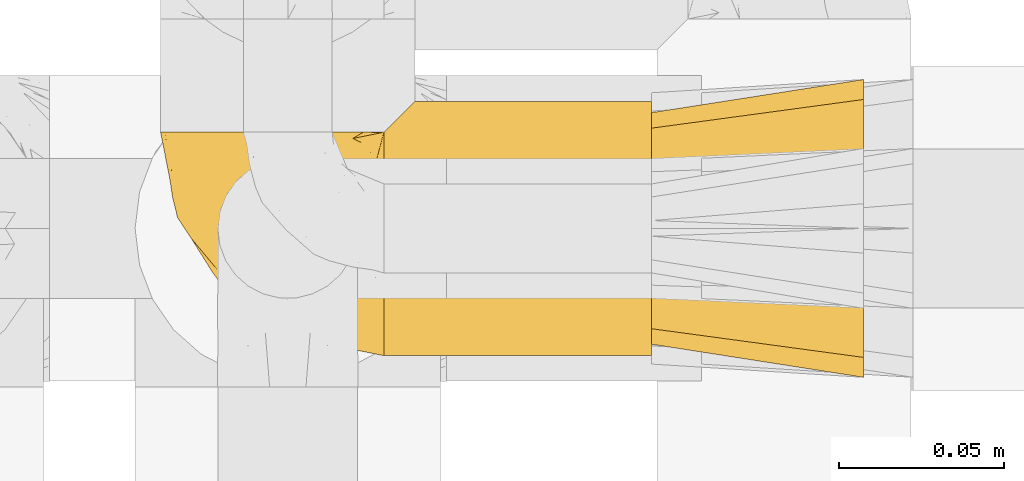
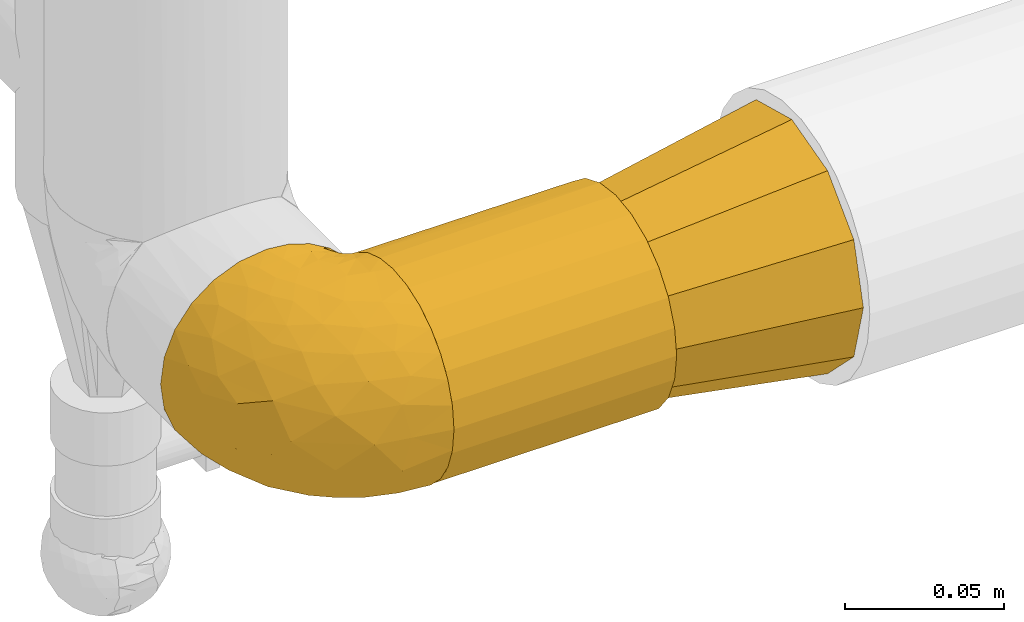
# One storey, part 434 of 827: 3 coverings.
"""IFC2X3 building model written with IfcOpenShell, lengths in millimetres."""

import ifcopenshell
import ifcopenshell.guid

model = None  # the IFC model being written
_history = None  # IfcOwnerHistory: only IFC2X3 demands one
_inside = {}  # id of a spatial element -> (the spatial element, [elements in it])
_under = {}  # id of a project, library or spatial element -> (it, [spatial elements below it])
_declared = {}  # id of a project -> (the project, [libraries it declares])
_typed = {}  # id of a type object -> (the type object, [elements of that type])
_made_of = {}  # id of a material, layer set ... -> (it, [elements and type objects made of it])


def new_model(schema):
    """Start an empty IFC model of exactly this schema.

    Asked for "IFC4X3", IfcOpenShell would pick the latest addendum, in which some entities
    have other attributes; the version numbers below select the first issue.
    IFC2X3 requires an IfcOwnerHistory on every rooted entity: one is made here for all.
    """
    global model, _history
    if schema == "IFC4X3":
        model = ifcopenshell.file(schema_version=(4, 3, 0, 0))
    else:
        model = ifcopenshell.file(schema=schema)
    _inside.clear()
    _under.clear()
    _declared.clear()
    _typed.clear()
    _made_of.clear()
    _history = None
    if model.schema == "IFC2X3":
        org = make("IfcOrganization", Name="unknown")
        user = make(
            "IfcPersonAndOrganization",
            ThePerson=make("IfcPerson", FamilyName="unknown"),
            TheOrganization=org,
        )
        app = make(
            "IfcApplication",
            ApplicationDeveloper=org,
            Version="unknown",
            ApplicationFullName="unknown",
            ApplicationIdentifier="unknown",
        )
        _history = make(
            "IfcOwnerHistory",
            OwningUser=user,
            OwningApplication=app,
            ChangeAction="ADDED",
            CreationDate=0,
        )
    return model


def make(cls, **values):
    """One entity of the class cls with the attributes given. An attribute that is None is left unset."""
    return model.create_entity(
        cls, **{name: value for name, value in values.items() if value is not None}
    )


def entity(cls, *values):
    """Any entity or typed value of the class cls, its attributes in the order of the schema. None: left unset."""
    e = model.create_entity(cls)
    for i, value in enumerate(values):
        if value is not None:
            e[i] = value
    return e


def rooted(cls, **values):
    """An entity with a GlobalId (a new one), such as an element, a storey or a relation."""
    return make(cls, GlobalId=ifcopenshell.guid.new(), OwnerHistory=_history, **values)


def si_unit(unit_type, name, prefix=None):
    """IfcSIUnit, for example si_unit("LENGTHUNIT", "METRE", prefix="MILLI")."""
    return make("IfcSIUnit", UnitType=unit_type, Prefix=prefix, Name=name)


def converted_unit(unit_type, name, factor, base, dimensions=None, offset=None):
    """IfcConversionBasedUnit, such as the inch: factor (a typed value) times the base unit."""
    return make(
        "IfcConversionBasedUnit"
        if offset is None
        else "IfcConversionBasedUnitWithOffset",
        ConversionOffset=offset,
        Dimensions=None
        if dimensions is None
        else entity("IfcDimensionalExponents", *dimensions),
        UnitType=unit_type,
        Name=name,
        ConversionFactor=make(
            "IfcMeasureWithUnit", ValueComponent=factor, UnitComponent=base
        ),
    )


def derived_unit(unit_type, elements):
    """IfcDerivedUnit: a product of units, each with its exponent."""
    return make(
        "IfcDerivedUnit",
        Elements=[
            make("IfcDerivedUnitElement", Unit=unit, Exponent=power)
            for unit, power in elements
        ],
        UnitType=unit_type,
    )


def assignment(units):
    """IfcUnitAssignment: the units of a project."""
    return None if units is None else make("IfcUnitAssignment", Units=units)


def point(xyz):
    """IfcCartesianPoint."""
    return None if xyz is None else make("IfcCartesianPoint", Coordinates=xyz)


def direction(xyz):
    """IfcDirection."""
    return None if xyz is None else make("IfcDirection", DirectionRatios=xyz)


def frame(location, z_axis=None, x_axis=None):
    """IfcAxis2Placement3D, a coordinate frame: its origin and axes. An axis left out is left unset."""
    return make(
        "IfcAxis2Placement3D",
        Location=point(location),
        Axis=direction(z_axis),
        RefDirection=direction(x_axis),
    )


def origin():
    """The frame at (0, 0, 0) with its axes left unset."""
    return frame((0.0, 0.0, 0.0))


def place(relative_to, where):
    """IfcLocalPlacement: puts the frame where relative to a parent placement (None: the world)."""
    return make(
        "IfcLocalPlacement", PlacementRelTo=relative_to, RelativePlacement=where
    )


def context(
    kind, dimensions, precision=None, world=None, true_north=None, identifier=None
):
    """IfcGeometricRepresentationContext, for example the 3D "Model" context."""
    return make(
        "IfcGeometricRepresentationContext",
        ContextIdentifier=identifier,
        ContextType=kind,
        CoordinateSpaceDimension=dimensions,
        Precision=precision,
        WorldCoordinateSystem=world,
        TrueNorth=true_north,
    )


def subcontext(parent, identifier, kind, view, scale=None):
    """IfcGeometricRepresentationSubContext, for example "Body" below "Model"."""
    return make(
        "IfcGeometricRepresentationSubContext",
        ContextIdentifier=identifier,
        ContextType=kind,
        ParentContext=parent,
        TargetScale=scale,
        TargetView=view,
    )


def project(units=None, contexts=None):
    """IfcProject with its units and contexts."""
    return rooted(
        "IfcProject",
        Name="project",
        RepresentationContexts=contexts,
        UnitsInContext=assignment(units),
    )


def spatial(cls, under=None, at=None, **own):
    """A site, building, storey or space (cls), placed at a placement, below another one or the project."""
    s = rooted(cls, ObjectPlacement=at, **own)
    if under is not None:
        _under.setdefault(under.id(), (under, []))[1].append(s)
    return s


def faces_of(points, faces, orient=None, outer=None):
    """IfcFace entities. A face is a list of loops; a loop is a list of indices into points, from 0.

    orient and outer hold one flag for each loop. By default every Orientation is true, the
    first loop of a face is its IfcFaceOuterBound and the others are IfcFaceBound.
    """
    made = []
    for i, loops in enumerate(faces):
        bounds = []
        for j, loop in enumerate(loops):
            is_outer = j == 0 if outer is None else outer[i][j]
            bounds.append(
                make(
                    "IfcFaceOuterBound" if is_outer else "IfcFaceBound",
                    Bound=make("IfcPolyLoop", Polygon=[points[k] for k in loop]),
                    Orientation=True if orient is None else orient[i][j],
                )
            )
        made.append(make("IfcFace", Bounds=bounds))
    return made


def faceted_brep(points, faces, orient=None, outer=None, voids=None):
    """IfcFacetedBrep: a solid bounded by flat faces; with voids (closed shells), ...WithVoids."""
    shared = [point(p) for p in points]
    hull = make("IfcClosedShell", CfsFaces=faces_of(shared, faces, orient, outer))
    if voids is None:
        return make("IfcFacetedBrep", Outer=hull)
    return make(
        "IfcFacetedBrepWithVoids",
        Outer=hull,
        Voids=[
            make(cls, CfsFaces=faces_of(shared, fs, o, b)) for cls, fs, o, b in voids
        ],
    )


def shape(context_of_items, identifier, shape_type, items):
    """IfcShapeRepresentation: the items that make up one representation, for example the "Body"."""
    return make(
        "IfcShapeRepresentation",
        ContextOfItems=context_of_items,
        RepresentationIdentifier=identifier,
        RepresentationType=shape_type,
        Items=items,
    )


def made_of(thing, what):
    """Note that an element or type object is made of a material, layer set ...; save() writes the relation."""
    if what is not None:
        _made_of.setdefault(what.id(), (what, []))[1].append(thing)
    return thing


def element(
    cls,
    number,
    at=None,
    inside=None,
    cuts=None,
    type_object=None,
    material=None,
    context=None,
    identifier="Body",
    shape_type=None,
    held_by="IfcProductDefinitionShape",
    body=None,
    shapes=None,
    **own,
):
    """One element of the class cls, such as IfcWall. Its Tag is "e" and its number.

    at: its placement. inside: the storey or other place that contains it. cuts: it is an
    opening in that element (IfcRelVoidsElement). A single representation is given by context,
    identifier, shape_type and body (its items); several are given by shapes. held_by: the class
    of the entity that holds the representations. save() writes the other relations.
    """
    e = rooted(cls, Tag="e%d" % number, ObjectPlacement=at, **own)
    if body is not None:
        shapes = [shape(context, identifier, shape_type, body)]
    if shapes is not None:
        e.Representation = make(held_by, Representations=shapes)
    if inside is not None:
        _inside.setdefault(inside.id(), (inside, []))[1].append(e)
    if cuts is not None:
        rooted(
            "IfcRelVoidsElement", RelatingBuildingElement=cuts, RelatedOpeningElement=e
        )
    if type_object is not None:
        _typed.setdefault(type_object.id(), (type_object, []))[1].append(e)
    return made_of(e, material)


def aggregate(whole, parts):
    """IfcRelAggregates: a whole, such as a stair, and the parts it consists of."""
    return rooted("IfcRelAggregates", RelatingObject=whole, RelatedObjects=parts)


def save(model, path):
    """Write the relations noted so far, then the file.

    IfcRelAggregates (storeys below a building ...), IfcRelContainedInSpatialStructure (elements
    in a storey), IfcRelDefinesByType, IfcRelAssociatesMaterial and IfcRelDeclares: one each for
    every whole, place, type object, material and project.
    """
    for whole, parts in _under.values():
        aggregate(whole, parts)
    for where, things in _inside.values():
        rooted(
            "IfcRelContainedInSpatialStructure",
            RelatedElements=things,
            RelatingStructure=where,
        )
    for kind, things in _typed.values():
        rooted("IfcRelDefinesByType", RelatedObjects=things, RelatingType=kind)
    for what, things in _made_of.values():
        rooted("IfcRelAssociatesMaterial", RelatedObjects=things, RelatingMaterial=what)
    for by, libraries in _declared.values():
        rooted("IfcRelDeclares", RelatingContext=by, RelatedDefinitions=libraries)
    model.write(path)


model = new_model("IFC2X3")

# Units and contexts
model_context = context("Model", 3, precision=0.01, world=origin(), true_north=direction((6.12303176911189e-17, 1.0)))
body_context = subcontext(model_context, "Body", "Model", "MODEL_VIEW")
ifc_project = project(units=[si_unit("LENGTHUNIT", "METRE", prefix="MILLI"), si_unit("AREAUNIT", "SQUARE_METRE"), si_unit("VOLUMEUNIT", "CUBIC_METRE"), converted_unit("PLANEANGLEUNIT", "DEGREE", entity("IfcRatioMeasure", 0.0174532925199433), si_unit("PLANEANGLEUNIT", "RADIAN"), dimensions=[0, 0, 0, 0, 0, 0, 0]), si_unit("MASSUNIT", "GRAM", prefix="KILO"), derived_unit("MASSDENSITYUNIT", [(si_unit("MASSUNIT", "GRAM", prefix="KILO"), 1), (si_unit("LENGTHUNIT", "METRE"), -3)]), derived_unit("MOMENTOFINERTIAUNIT", [(si_unit("LENGTHUNIT", "METRE"), 4)]), si_unit("TIMEUNIT", "SECOND"), si_unit("FREQUENCYUNIT", "HERTZ"), si_unit("THERMODYNAMICTEMPERATUREUNIT", "DEGREE_CELSIUS"), derived_unit("THERMALTRANSMITTANCEUNIT", [(si_unit("MASSUNIT", "GRAM", prefix="KILO"), 1), (si_unit("THERMODYNAMICTEMPERATUREUNIT", "KELVIN"), -1), (si_unit("TIMEUNIT", "SECOND"), -3)]), derived_unit("VOLUMETRICFLOWRATEUNIT", [(si_unit("LENGTHUNIT", "METRE"), 3), (si_unit("TIMEUNIT", "SECOND"), -1)]), derived_unit("MASSFLOWRATEUNIT", [(si_unit("MASSUNIT", "GRAM", prefix="KILO"), 1), (si_unit("TIMEUNIT", "SECOND"), -1)]), derived_unit("ROTATIONALFREQUENCYUNIT", [(si_unit("TIMEUNIT", "SECOND"), -1)]), si_unit("ELECTRICCURRENTUNIT", "AMPERE"), si_unit("ELECTRICVOLTAGEUNIT", "VOLT"), si_unit("POWERUNIT", "WATT"), si_unit("FORCEUNIT", "NEWTON", prefix="KILO"), si_unit("ILLUMINANCEUNIT", "LUX"), si_unit("LUMINOUSFLUXUNIT", "LUMEN"), si_unit("LUMINOUSINTENSITYUNIT", "CANDELA"), derived_unit("USERDEFINED", [(si_unit("MASSUNIT", "GRAM", prefix="KILO"), -1), (si_unit("LENGTHUNIT", "METRE"), -2), (si_unit("TIMEUNIT", "SECOND"), 3), (si_unit("LUMINOUSFLUXUNIT", "LUMEN"), 1)]), derived_unit("LINEARVELOCITYUNIT", [(si_unit("LENGTHUNIT", "METRE"), 1), (si_unit("TIMEUNIT", "SECOND"), -1)]), si_unit("PRESSUREUNIT", "PASCAL"), derived_unit("USERDEFINED", [(si_unit("LENGTHUNIT", "METRE"), -2), (si_unit("MASSUNIT", "GRAM", prefix="KILO"), 1), (si_unit("TIMEUNIT", "SECOND"), -2)]), derived_unit("LINEARFORCEUNIT", [(si_unit("MASSUNIT", "GRAM", prefix="KILO"), 1), (si_unit("LENGTHUNIT", "METRE"), 1), (si_unit("TIMEUNIT", "SECOND"), -2), (si_unit("LENGTHUNIT", "METRE"), -1)]), derived_unit("PLANARFORCEUNIT", [(si_unit("MASSUNIT", "GRAM", prefix="KILO"), 1), (si_unit("LENGTHUNIT", "METRE"), 1), (si_unit("TIMEUNIT", "SECOND"), -2), (si_unit("LENGTHUNIT", "METRE"), -2)])], contexts=[model_context])

# Site, building, storey
site_placement = place(None, origin())
site = spatial("IfcSite", under=ifc_project, at=site_placement, CompositionType="ELEMENT")
building_placement = place(site_placement, origin())
building = spatial("IfcBuilding", under=site, at=building_placement, CompositionType="ELEMENT")
storey_placement = place(building_placement, frame((0.0, 0.0, 28200.0)))
storey = spatial("IfcBuildingStorey", under=building, at=storey_placement, Name="08", CompositionType="ELEMENT", Elevation=28200.0)

# Coverings
covering_1_placement = place(storey_placement, frame((54217.29, 17460.0, 1330.0)))
element("IfcCovering", 1, at=covering_1_placement, inside=storey, Name=":ADSK_", ObjectType=":ADSK_", PredefinedType="INSULATION", context=body_context, shape_type="Brep", body=[
    faceted_brep([(1.6, 20.8, 6.74), (1.6, 12.84, 12.84), (1.6, 6.74, 20.8), (1.6, 2.9, 30.06), (1.6, 1.6, 40.0), (1.6, 2.9, 49.93), (1.6, 6.74, 59.2), (1.6, 12.84, 67.15), (1.6, 20.8, 73.25), (1.6, 30.06, 77.09), (1.6, 40.0, 78.4), (1.6, 48.2, 77.51), (1.6, 56.01, 74.9), (1.6, 63.08, 70.68), (1.6, 69.1, 65.05), (1.6, 69.1, 14.94), (1.6, 63.08, 9.31), (1.6, 56.01, 5.09), (1.6, 48.2, 2.48), (1.6, 40.0, 1.6), (1.6, 30.06, 2.9), (82.5, 20.8, 6.74), (82.5, 30.06, 2.9), (82.5, 40.0, 1.6), (82.5, 49.93, 2.9), (82.5, 59.2, 6.74), (82.5, 67.15, 12.84), (82.5, 73.25, 20.8), (82.5, 77.09, 30.06), (82.5, 78.4, 40.0), (82.5, 77.09, 49.93), (82.5, 73.25, 59.2), (82.5, 67.15, 67.15), (82.5, 59.2, 73.25), (82.5, 49.93, 77.09), (82.5, 40.0, 78.4), (82.5, 30.06, 77.09), (82.5, 20.8, 73.25), (82.5, 12.84, 67.15), (82.5, 6.74, 59.2), (82.5, 2.9, 49.93), (82.5, 1.6, 40.0), (82.5, 2.9, 30.06), (82.5, 6.74, 20.8), (82.5, 12.84, 12.84), (10.29, 77.79, 33.21), (10.9, 78.4, 40.0), (8.5, 76.0, 26.63), (5.57, 73.07, 20.48), (8.5, 76.0, 53.36), (10.29, 77.79, 46.78), (5.57, 73.07, 59.51)], [[[0, 1, 2, 3, 4, 5, 6, 7, 8, 9, 10, 11, 12, 13, 14, 15, 16, 17, 18, 19, 20]], [[21, 22, 23, 24, 25, 26, 27, 28, 29, 30, 31, 32, 33, 34, 35, 36, 37, 38, 39, 40, 41, 42, 43, 44]], [[45, 46, 29]], [[45, 29, 28]], [[47, 28, 27]], [[47, 45, 28]], [[15, 48, 27]], [[47, 27, 48]], [[27, 26, 15]], [[16, 26, 25]], [[17, 25, 24]], [[18, 24, 23]], [[16, 25, 17]], [[17, 24, 18]], [[23, 19, 18]], [[26, 16, 15]], [[20, 19, 23, 22]], [[0, 20, 22, 21]], [[21, 44, 1, 0]], [[3, 2, 43, 42]], [[4, 3, 42, 41]], [[44, 43, 2, 1]], [[5, 4, 41, 40]], [[6, 5, 40, 39]], [[39, 38, 7, 6]], [[9, 8, 37, 36]], [[10, 9, 36, 35]], [[38, 37, 8, 7]], [[11, 35, 34]], [[12, 34, 33]], [[13, 33, 32]], [[10, 35, 11]], [[11, 34, 12]], [[33, 13, 12]], [[32, 14, 13]], [[49, 31, 30]], [[30, 29, 50]], [[46, 50, 29]], [[51, 14, 31]], [[50, 49, 30]], [[51, 31, 49]], [[31, 14, 32]], [[14, 51, 49, 50, 46, 45, 47, 48, 15]]]),
])
covering_2_placement = place(storey_placement, frame((54149.74, 17459.95, 1329.95)))
element("IfcCovering", 2, at=covering_2_placement, inside=storey, Name=":ADSK_", ObjectType=":ADSK_", PredefinedType="INSULATION", context=body_context, shape_type="Brep", body=[
    faceted_brep([(69.15, 23.36, 74.68), (69.15, 16.07, 70.1), (69.15, 9.98, 64.01), (69.15, 5.4, 56.72), (69.15, 2.56, 48.6), (69.15, 1.6, 40.05), (69.15, 2.56, 31.49), (69.15, 5.41, 23.36), (69.15, 9.99, 16.07), (69.15, 16.08, 9.98), (69.15, 23.37, 5.4), (69.15, 31.49, 2.56), (69.15, 40.05, 1.6), (69.15, 48.15, 2.46), (69.15, 55.88, 5.01), (69.15, 62.9, 9.13), (69.15, 68.89, 14.62), (69.15, 68.89, 16.82), (69.15, 68.89, 18.56), (69.15, 68.89, 20.52), (69.15, 68.89, 22.49), (69.15, 68.89, 24.46), (69.15, 68.89, 26.42), (69.15, 68.89, 28.39), (69.15, 68.89, 30.36), (69.15, 68.89, 32.55), (69.15, 68.89, 34.75), (69.15, 68.89, 36.94), (69.15, 68.89, 39.13), (69.15, 68.89, 41.33), (69.15, 68.89, 43.52), (69.15, 68.89, 45.72), (69.15, 68.89, 47.91), (69.15, 68.89, 50.11), (69.15, 68.89, 52.3), (69.15, 68.89, 54.49), (69.15, 68.89, 56.69), (69.15, 68.89, 58.88), (69.15, 68.89, 61.08), (69.15, 68.89, 63.27), (69.15, 68.89, 65.47), (69.15, 62.89, 70.97), (69.15, 55.86, 75.09), (69.15, 48.13, 77.64), (69.15, 40.05, 78.5), (69.15, 31.49, 77.53), (68.89, 69.15, 14.62), (62.89, 69.15, 9.12), (55.87, 69.15, 5.0), (48.14, 69.15, 2.46), (40.05, 69.15, 1.6), (30.09, 69.15, 2.91), (20.82, 69.15, 6.75), (12.86, 69.15, 12.86), (6.75, 69.15, 20.82), (2.91, 69.15, 30.09), (1.6, 69.15, 40.05), (2.91, 69.15, 50.0), (6.75, 69.15, 59.27), (12.86, 69.15, 67.23), (20.82, 69.15, 73.34), (30.09, 69.15, 77.19), (40.05, 69.15, 78.5), (48.14, 69.15, 77.63), (55.87, 69.15, 75.09), (62.89, 69.15, 70.97), (68.89, 69.15, 65.47), (68.89, 69.15, 63.27), (68.89, 69.15, 62.29), (68.89, 69.15, 60.7), (68.89, 69.15, 59.11), (68.89, 69.15, 57.52), (68.89, 69.15, 55.93), (68.89, 69.15, 54.34), (68.89, 69.15, 52.76), (68.89, 69.15, 51.17), (68.89, 69.15, 49.58), (68.89, 69.15, 47.99), (68.89, 69.15, 46.4), (68.89, 69.15, 44.81), (68.89, 69.15, 43.22), (68.89, 69.15, 41.63), (68.89, 69.15, 40.05), (68.89, 69.15, 38.46), (68.89, 69.15, 36.87), (68.89, 69.15, 35.28), (68.89, 69.15, 33.69), (68.89, 69.15, 32.1), (68.89, 69.15, 30.51), (68.89, 69.15, 28.92), (68.89, 69.15, 27.33), (68.89, 69.15, 25.37), (68.89, 69.15, 23.4), (68.89, 69.15, 21.21), (68.89, 69.15, 19.01), (68.89, 69.15, 16.82), (68.97, 68.96, 42.32), (68.96, 68.97, 44.02), (68.97, 68.97, 47.13), (68.97, 68.97, 48.74), (68.98, 68.95, 23.57), (68.97, 68.96, 25.13), (68.96, 68.98, 61.34), (68.96, 68.97, 22.02), (68.96, 68.97, 29.72), (68.96, 68.98, 56.73), (68.96, 68.97, 55.14), (68.96, 68.97, 37.66), (69.0, 68.94, 64.12), (68.96, 68.98, 28.13), (68.96, 68.98, 26.62), (68.97, 68.96, 31.46), (68.96, 68.97, 16.16), (68.96, 68.98, 39.16), (68.96, 68.98, 50.37), (68.97, 68.97, 17.69), (68.97, 68.96, 19.17), (68.97, 68.97, 62.78), (68.96, 68.97, 58.35), (68.96, 68.98, 45.53), (68.97, 68.96, 59.91), (68.97, 68.97, 65.47), (69.02, 68.94, 65.47), (69.08, 68.92, 65.47), (68.97, 68.97, 14.62), (68.94, 69.02, 14.62), (68.92, 69.08, 14.62), (68.96, 68.98, 20.59), (68.96, 68.97, 32.99), (68.95, 68.98, 34.48), (68.96, 68.97, 51.91), (68.92, 69.08, 65.47), (68.94, 69.02, 65.47), (68.98, 68.96, 53.48), (69.08, 68.92, 14.62), (69.02, 68.94, 14.62), (68.96, 68.97, 40.77), (68.97, 68.96, 35.97), (61.33, 67.02, 7.84), (53.1, 63.33, 3.53), (63.33, 64.61, 8.32), (49.27, 49.27, 1.6), (55.53, 51.4, 2.19), (54.6, 43.94, 1.6), (41.99, 61.87, 1.6), (57.07, 61.54, 4.57), (57.95, 57.95, 3.96), (51.56, 56.12, 2.28), (41.58, 63.4, 1.6), (61.7, 65.41, 7.69), (63.33, 53.1, 3.53), (65.0, 63.04, 8.32), (67.02, 61.33, 7.84), (61.87, 41.99, 1.6), (43.94, 54.6, 1.6), (61.21, 56.6, 4.34), (63.4, 41.58, 1.6), (33.11, 13.72, 29.63), (52.82, 5.82, 27.34), (43.3, 6.74, 40.05), (33.73, 58.82, 2.39), (36.52, 51.58, 2.43), (24.87, 42.09, 9.07), (14.17, 46.12, 16.64), (18.43, 55.56, 9.54), (28.67, 52.38, 4.52), (26.0, 61.54, 4.52), (49.25, 23.76, 7.49), (59.72, 20.5, 7.49), (55.1, 14.64, 12.85), (44.72, 41.77, 2.35), (34.15, 16.28, 22.66), (5.25, 49.4, 32.9), (6.75, 52.34, 25.33), (55.54, 4.3, 40.05), (10.47, 58.67, 16.64), (25.49, 25.26, 19.99), (35.53, 20.17, 16.37), (48.22, 34.7, 3.26), (58.71, 28.67, 3.75), (57.42, 8.62, 19.58), (34.84, 33.37, 7.5), (36.87, 41.35, 4.04), (45.01, 17.15, 13.94), (44.4, 12.68, 19.58), (23.96, 21.47, 28.21), (11.2, 41.11, 24.75), (10.56, 37.53, 31.42), (16.81, 30.64, 26.2), (17.38, 26.66, 33.36), (21.38, 21.38, 40.05), (32.34, 14.06, 40.05), (4.3, 55.54, 40.05), (20.65, 35.17, 16.14), (29.66, 29.04, 12.85), (39.6, 24.34, 10.47), (42.55, 29.33, 6.49), (6.74, 43.3, 40.05), (14.06, 32.34, 40.05), (26.84, 57.75, 75.57), (5.28, 49.41, 47.37), (18.52, 27.85, 52.91), (33.13, 13.7, 50.46), (55.1, 14.63, 67.23), (57.43, 8.61, 60.5), (20.72, 48.85, 70.55), (11.46, 54.13, 63.45), (17.69, 37.84, 62.61), (49.26, 23.75, 72.6), (59.73, 20.49, 72.6), (58.71, 28.66, 76.34), (29.72, 20.83, 59.34), (35.35, 55.15, 77.76), (43.94, 54.6, 78.5), (41.99, 61.87, 78.5), (63.4, 41.58, 78.5), (4.93, 57.58, 53.16), (17.46, 59.91, 70.55), (10.94, 36.94, 48.88), (8.92, 45.72, 54.76), (52.83, 5.82, 52.74), (29.34, 37.91, 71.93), (30.26, 50.18, 75.79), (44.4, 12.67, 60.5), (39.06, 49.29, 77.86), (43.06, 42.64, 77.64), (54.6, 43.94, 78.5), (49.27, 49.27, 78.5), (42.69, 19.45, 67.23), (48.2, 34.7, 76.82), (61.87, 41.99, 78.5), (33.44, 62.29, 77.8), (29.67, 29.01, 67.23), (38.5, 31.47, 73.2), (23.35, 37.18, 67.66), (34.97, 43.45, 75.99), (53.1, 63.33, 76.57), (59.68, 67.23, 73.21), (62.19, 66.07, 71.93), (64.11, 65.22, 71.07), (57.97, 61.99, 75.09), (57.95, 57.95, 76.13), (63.33, 53.09, 76.57), (51.77, 56.84, 77.69), (67.02, 61.33, 72.26), (64.98, 63.06, 71.77), (55.53, 51.41, 77.9), (61.22, 56.61, 75.75)], [[[0, 1, 2, 3, 4, 5, 6, 7, 8, 9, 10, 11, 12, 13, 14, 15, 16, 17, 18, 19, 20, 21, 22, 23, 24, 25, 26, 27, 28, 29, 30, 31, 32, 33, 34, 35, 36, 37, 38, 39, 40, 41, 42, 43, 44, 45]], [[46, 47, 48, 49, 50, 51, 52, 53, 54, 55, 56, 57, 58, 59, 60, 61, 62, 63, 64, 65, 66, 67, 68, 69, 70, 71, 72, 73, 74, 75, 76, 77, 78, 79, 80, 81, 82, 83, 84, 85, 86, 87, 88, 89, 90, 91, 92, 93, 94, 95]], [[96, 97, 30]], [[98, 77, 99]], [[100, 101, 21]], [[69, 68, 102]], [[20, 19, 103]], [[24, 23, 104]], [[20, 103, 100]], [[72, 105, 106]], [[84, 83, 107]], [[89, 88, 104]], [[108, 67, 66]], [[109, 110, 90]], [[111, 25, 24]], [[112, 17, 16]], [[82, 113, 83]], [[109, 23, 22]], [[114, 76, 75]], [[105, 36, 106]], [[104, 111, 24]], [[18, 115, 116]], [[97, 96, 80]], [[67, 108, 117]], [[105, 71, 118]], [[31, 97, 119]], [[102, 120, 69]], [[108, 121, 122, 123, 40]], [[112, 95, 115]], [[17, 115, 18]], [[94, 116, 115]], [[117, 68, 67]], [[38, 117, 39]], [[112, 124, 125, 126, 46]], [[17, 112, 115]], [[70, 120, 118]], [[39, 117, 108]], [[120, 38, 37]], [[120, 37, 118]], [[120, 70, 69]], [[116, 94, 127]], [[128, 86, 129]], [[117, 38, 102]], [[74, 130, 75]], [[99, 33, 32]], [[115, 95, 94]], [[39, 108, 40]], [[108, 66, 131, 132, 121]], [[105, 72, 71]], [[118, 37, 36]], [[71, 70, 118]], [[35, 106, 36]], [[36, 105, 118]], [[35, 133, 106]], [[74, 73, 133]], [[106, 133, 73]], [[99, 114, 33]], [[133, 35, 34]], [[73, 72, 106]], [[95, 112, 46]], [[112, 16, 134, 135, 124]], [[130, 114, 75]], [[99, 76, 114]], [[114, 130, 33]], [[34, 33, 130]], [[78, 77, 98]], [[98, 119, 78]], [[130, 133, 34]], [[133, 130, 74]], [[79, 97, 80]], [[98, 99, 32]], [[98, 32, 31]], [[77, 76, 99]], [[97, 79, 119]], [[136, 96, 29]], [[30, 97, 31]], [[136, 29, 28]], [[81, 80, 96]], [[29, 96, 30]], [[31, 119, 98]], [[119, 79, 78]], [[96, 136, 81]], [[82, 81, 136]], [[113, 107, 83]], [[84, 107, 137]], [[107, 27, 137]], [[113, 28, 107]], [[27, 107, 28]], [[85, 84, 137]], [[137, 27, 26]], [[113, 136, 28]], [[136, 113, 82]], [[109, 89, 104]], [[86, 85, 129]], [[89, 109, 90]], [[111, 87, 128]], [[26, 129, 137]], [[88, 111, 104]], [[25, 111, 128]], [[22, 110, 109]], [[23, 109, 104]], [[110, 91, 90]], [[100, 92, 101]], [[110, 22, 101]], [[91, 110, 101]], [[116, 19, 18]], [[111, 88, 87]], [[127, 103, 19]], [[25, 128, 26]], [[86, 128, 87]], [[128, 129, 26]], [[137, 129, 85]], [[120, 102, 38]], [[117, 102, 68]], [[91, 101, 92]], [[21, 101, 22]], [[93, 92, 103]], [[100, 21, 20]], [[100, 103, 92]], [[127, 93, 103]], [[93, 127, 94]], [[116, 127, 19]], [[126, 138, 47]], [[48, 138, 139]], [[140, 125, 124]], [[141, 142, 143]], [[144, 49, 139]], [[145, 140, 146]], [[48, 139, 49]], [[139, 145, 147]], [[49, 144, 148, 50]], [[126, 125, 149]], [[14, 13, 150]], [[151, 146, 140]], [[149, 140, 145]], [[152, 151, 135]], [[152, 14, 150]], [[16, 15, 134]], [[13, 153, 150]], [[124, 151, 140]], [[141, 147, 142]], [[14, 152, 15]], [[15, 152, 134]], [[47, 46, 126]], [[139, 154, 144]], [[138, 48, 47]], [[125, 140, 149]], [[135, 134, 152]], [[146, 155, 142]], [[145, 146, 147]], [[149, 139, 138]], [[147, 141, 154]], [[147, 146, 142]], [[139, 147, 154]], [[139, 149, 145]], [[149, 138, 126]], [[155, 146, 151]], [[150, 143, 142]], [[152, 155, 151]], [[150, 142, 155]], [[13, 12, 156, 153]], [[153, 143, 150]], [[152, 150, 155]], [[151, 124, 135]], [[157, 158, 159]], [[160, 154, 161]], [[162, 163, 164]], [[165, 166, 160]], [[167, 168, 169]], [[141, 170, 161]], [[156, 12, 11]], [[158, 157, 171]], [[172, 55, 173]], [[158, 6, 174]], [[175, 54, 53]], [[52, 166, 164]], [[52, 164, 53]], [[54, 175, 173]], [[166, 52, 51]], [[176, 177, 171]], [[178, 143, 179]], [[156, 11, 179]], [[8, 7, 180]], [[169, 9, 8]], [[179, 143, 153, 156]], [[179, 11, 10]], [[168, 179, 10]], [[181, 162, 182]], [[179, 167, 178]], [[183, 184, 177]], [[183, 169, 184]], [[176, 171, 185]], [[172, 186, 187]], [[158, 7, 6]], [[159, 158, 174]], [[184, 180, 158]], [[54, 173, 55]], [[180, 169, 8]], [[188, 189, 187]], [[9, 168, 10]], [[186, 188, 187]], [[190, 157, 159, 191]], [[55, 172, 192]], [[176, 193, 194]], [[161, 170, 182]], [[162, 164, 165]], [[175, 164, 163]], [[51, 50, 148]], [[167, 195, 196]], [[178, 182, 170]], [[6, 5, 174]], [[158, 180, 7]], [[169, 180, 184]], [[169, 168, 9]], [[179, 168, 167]], [[182, 162, 165]], [[162, 194, 193]], [[161, 165, 160]], [[195, 181, 196]], [[192, 172, 197]], [[192, 56, 55]], [[189, 190, 198]], [[198, 197, 187]], [[172, 187, 197]], [[185, 189, 188]], [[198, 187, 189]], [[186, 172, 173]], [[173, 163, 186]], [[193, 186, 163]], [[176, 185, 188]], [[185, 157, 190]], [[188, 186, 193]], [[177, 176, 194]], [[188, 193, 176]], [[162, 193, 163]], [[195, 177, 194]], [[171, 177, 184]], [[181, 195, 194]], [[183, 167, 169]], [[162, 181, 194]], [[196, 182, 178]], [[158, 171, 184]], [[171, 157, 185]], [[177, 195, 183]], [[167, 183, 195]], [[182, 196, 181]], [[178, 170, 143]], [[178, 167, 196]], [[164, 175, 53]], [[173, 175, 163]], [[160, 51, 148]], [[164, 166, 165]], [[51, 160, 166]], [[160, 148, 144, 154]], [[141, 161, 154]], [[182, 165, 161]], [[190, 189, 185]], [[143, 170, 141]], [[60, 199, 61]], [[197, 200, 192]], [[201, 190, 202]], [[200, 57, 192]], [[203, 204, 2]], [[205, 206, 207]], [[208, 209, 210]], [[211, 207, 201]], [[212, 213, 214]], [[45, 215, 210]], [[216, 206, 58]], [[45, 44, 215]], [[59, 217, 60]], [[60, 217, 199]], [[0, 45, 210]], [[218, 201, 219]], [[202, 159, 220]], [[205, 221, 222]], [[223, 204, 203]], [[1, 203, 2]], [[57, 200, 216]], [[220, 3, 204]], [[220, 174, 4]], [[1, 0, 209]], [[212, 224, 213]], [[225, 226, 227]], [[228, 223, 203]], [[208, 210, 229]], [[210, 226, 229]], [[3, 220, 4]], [[58, 206, 59]], [[209, 203, 1]], [[202, 220, 223]], [[228, 203, 208]], [[202, 211, 201]], [[3, 2, 204]], [[202, 190, 191, 159]], [[210, 215, 230, 226]], [[199, 212, 231]], [[232, 233, 221]], [[233, 208, 229]], [[207, 206, 219]], [[217, 206, 205]], [[227, 224, 225]], [[233, 232, 228]], [[201, 207, 219]], [[234, 232, 221]], [[218, 219, 200]], [[202, 223, 211]], [[174, 220, 159]], [[174, 5, 4]], [[61, 231, 62]], [[220, 204, 223]], [[210, 209, 0]], [[203, 209, 208]], [[225, 233, 229]], [[224, 227, 213]], [[221, 233, 235]], [[57, 56, 192]], [[198, 218, 197]], [[200, 219, 216]], [[201, 198, 190]], [[197, 218, 200]], [[198, 201, 218]], [[206, 216, 219]], [[58, 57, 216]], [[231, 212, 214]], [[222, 212, 199]], [[228, 211, 223]], [[207, 211, 232]], [[62, 231, 214]], [[199, 231, 61]], [[233, 228, 208]], [[211, 228, 232]], [[222, 221, 235]], [[234, 205, 207]], [[206, 217, 59]], [[199, 217, 205]], [[205, 222, 199]], [[224, 222, 235]], [[222, 224, 212]], [[224, 235, 225]], [[233, 225, 235]], [[226, 225, 229]], [[205, 234, 221]], [[207, 232, 234]], [[63, 214, 236]], [[214, 213, 236]], [[214, 63, 62]], [[237, 236, 238]], [[238, 132, 131]], [[236, 237, 64]], [[239, 240, 241]], [[63, 236, 64]], [[131, 66, 65]], [[237, 131, 65]], [[242, 230, 43]], [[237, 65, 64]], [[239, 121, 132]], [[42, 242, 43]], [[241, 240, 243]], [[41, 123, 244]], [[43, 230, 215, 44]], [[244, 122, 245]], [[227, 246, 243]], [[241, 243, 246]], [[121, 239, 245]], [[41, 40, 123]], [[132, 238, 239]], [[244, 42, 41]], [[131, 237, 238]], [[240, 239, 238]], [[245, 239, 241]], [[247, 241, 246]], [[247, 244, 245]], [[238, 236, 240]], [[243, 236, 213]], [[236, 243, 240]], [[226, 246, 227]], [[243, 213, 227]], [[226, 242, 246]], [[241, 247, 245]], [[246, 242, 247]], [[244, 247, 242]], [[242, 226, 230]], [[42, 244, 242]], [[122, 244, 123]], [[122, 121, 245]]]),
])
covering_3_placement = place(storey_placement, frame((54299.79, 17453.4, 1323.4)))
element("IfcCovering", 3, at=covering_3_placement, inside=storey, Name=":ADSK_", ObjectType=":ADSK_", PredefinedType="INSULATION", context=body_context, shape_type="Brep", body=[
    faceted_brep([(64.0, 15.86, 77.33), (64.0, 7.62, 69.1), (64.0, 5.02, 59.38), (64.0, 1.6, 46.6), (64.0, 5.02, 33.81), (64.0, 7.62, 24.1), (64.0, 15.86, 15.86), (64.0, 24.1, 7.62), (64.0, 33.81, 5.02), (64.0, 46.6, 1.6), (64.0, 59.38, 5.02), (64.0, 69.1, 7.62), (64.0, 77.33, 15.86), (64.0, 85.57, 24.1), (64.0, 88.17, 33.81), (64.0, 91.6, 46.6), (64.0, 88.17, 59.38), (64.0, 85.57, 69.1), (64.0, 77.33, 77.33), (64.0, 69.1, 85.57), (64.0, 59.38, 88.17), (64.0, 46.6, 91.6), (64.0, 33.81, 88.17), (64.0, 24.1, 85.57), (0.0, 64.1, 76.91), (0.0, 70.5, 70.5), (0.0, 76.91, 64.1), (0.0, 79.25, 55.35), (0.0, 81.6, 46.6), (0.0, 79.25, 37.85), (0.0, 76.91, 29.1), (0.0, 70.5, 22.69), (0.0, 64.1, 16.28), (0.0, 55.35, 13.94), (0.0, 46.6, 11.6), (0.0, 37.85, 13.94), (0.0, 29.1, 16.28), (0.0, 22.69, 22.69), (0.0, 16.28, 29.1), (0.0, 13.94, 37.85), (0.0, 11.6, 46.6), (0.0, 13.94, 55.35), (0.0, 16.28, 64.1), (0.0, 22.69, 70.5), (0.0, 29.1, 76.91), (0.0, 37.85, 79.25), (0.0, 46.6, 81.6), (0.0, 55.35, 79.25)], [[[0, 1, 2, 3, 4, 5, 6, 7, 8, 9, 10, 11, 12, 13, 14, 15, 16, 17, 18, 19, 20, 21, 22, 23]], [[24, 25, 26, 27, 28, 29, 30, 31, 32, 33, 34, 35, 36, 37, 38, 39, 40, 41, 42, 43, 44, 45, 46, 47]], [[38, 5, 4, 3, 40, 39]], [[6, 5, 38, 37, 36, 7]], [[35, 34, 9, 8, 7, 36]], [[32, 11, 10, 9, 34, 33]], [[12, 11, 32, 31, 30, 13]], [[29, 28, 15, 14, 13, 30]], [[26, 17, 16, 15, 28, 27]], [[18, 17, 26, 25, 24, 19]], [[47, 46, 21, 20, 19, 24]], [[44, 23, 22, 21, 46, 45]], [[0, 23, 44, 43, 42, 1]], [[41, 40, 3, 2, 1, 42]]]),
])

save(model, "model.ifc")
